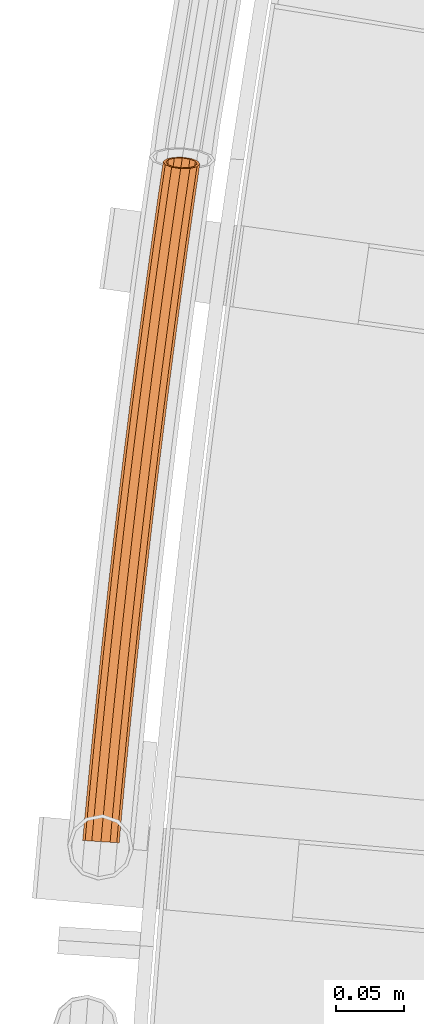
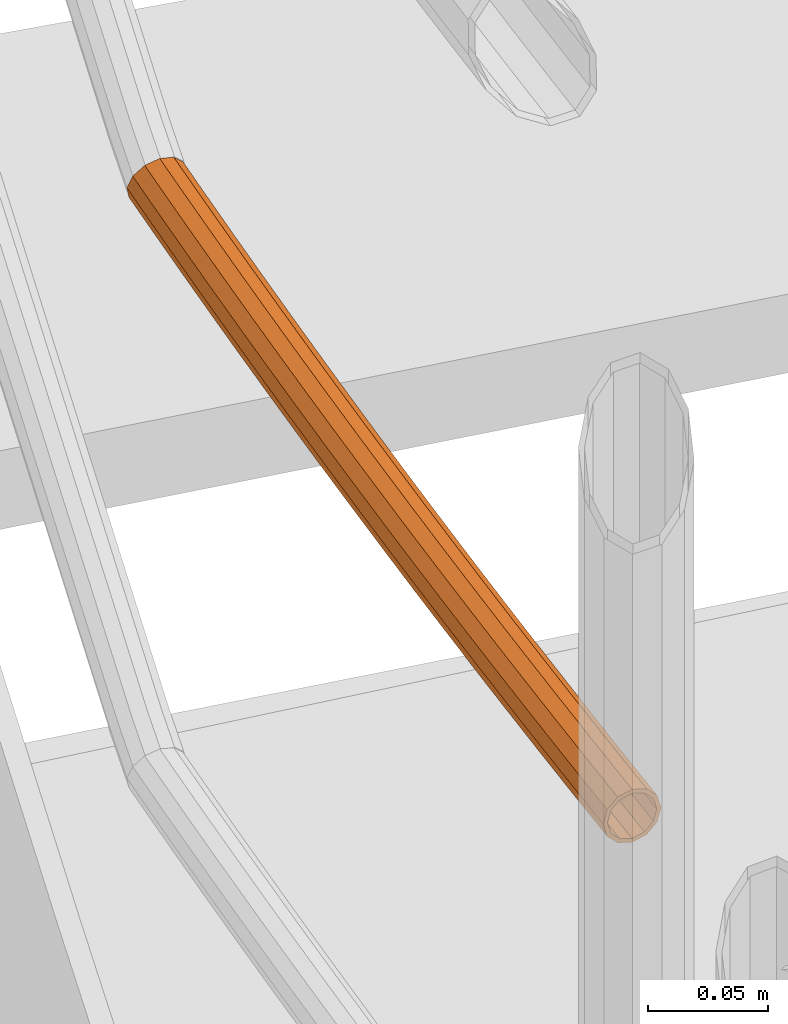
# One storey, part 59 of 126: 1 proxy.
"""IFC2X3 building model written with IfcOpenShell, lengths in millimetres."""

from ifc_helpers import new_model, si_unit, origin, origin_with_axes, place, context, project, spatial, faceted_brep, material, element, save


model = new_model("IFC2X3")

# Units and contexts
context_of_model_1 = context(None, 3, precision=0.1, world=origin())
context_of_model_2 = context(None, 3, precision=0.1, world=origin())
ifc_project = project(units=[si_unit("LENGTHUNIT", "METRE", prefix="MILLI"), si_unit("AREAUNIT", "SQUARE_METRE", prefix="CENTI"), si_unit("VOLUMEUNIT", "CUBIC_METRE", prefix="CENTI"), si_unit("MASSUNIT", "GRAM", prefix="KILO")], contexts=[context_of_model_1, context_of_model_2])

# Site, building, storey
site_placement = place(None, origin_with_axes())
site = spatial("IfcSite", under=ifc_project, at=site_placement, CompositionType="ELEMENT")
building_placement = place(site_placement, origin_with_axes())
building = spatial("IfcBuilding", under=site, at=building_placement, CompositionType="ELEMENT")
storey_placement = place(building_placement, origin_with_axes())
storey = spatial("IfcBuildingStorey", under=building, at=storey_placement, CompositionType="ELEMENT")

# Proxy
ifc_material = material(Name="S235JRG2")
proxy_placement = place(storey_placement, origin_with_axes())
element("IfcBuildingElementProxy", 1, at=proxy_placement, inside=storey, material=ifc_material, context=context_of_model_2, shape_type="Brep", body=[
    faceted_brep([(-835.646, 8812.6734, 6295.5551), (-833.8515, 8812.5095, 6288.8301), (-834.8889, 8800.9315, 6288.8301), (-836.6876, 8801.0484, 6295.5551), (-828.9489, 8812.0616, 6283.907), (-829.9748, 8800.612, 6283.907), (-822.2518, 8811.4498, 6282.1051), (-823.262, 8800.1755, 6282.1051), (-815.5547, 8810.8379, 6283.907), (-816.5491, 8799.7391, 6283.907), (-810.652, 8810.39, 6288.8301), (-811.635, 8799.4196, 6288.8301), (-808.8575, 8810.2261, 6295.5551), (-809.8363, 8799.3026, 6295.5551), (-810.652, 8810.39, 6302.2801), (-811.635, 8799.4196, 6302.2801), (-815.5547, 8810.8379, 6307.2031), (-816.5491, 8799.7391, 6307.2031), (-822.2518, 8811.4498, 6309.0051), (-823.262, 8800.1755, 6309.0051), (-828.9489, 8812.0616, 6307.2031), (-829.9748, 8800.612, 6307.2031), (-833.8515, 8812.5095, 6302.2801), (-834.8889, 8800.9315, 6302.2801), (-833.6543, 8812.4915, 6295.5551), (-832.1267, 8812.3519, 6301.2801), (-833.16, 8800.8191, 6301.2801), (-834.6912, 8800.9186, 6295.5551), (-827.9531, 8811.9706, 6305.4711), (-828.9766, 8800.5471, 6305.4711), (-822.2518, 8811.4498, 6307.0051), (-823.262, 8800.1755, 6307.0051), (-816.5505, 8810.9289, 6305.4711), (-817.5473, 8799.804, 6305.4711), (-812.3769, 8810.5476, 6301.2801), (-813.3639, 8799.532, 6301.2801), (-810.8493, 8810.408, 6295.5551), (-811.8327, 8799.4324, 6295.5551), (-812.3769, 8810.5476, 6289.8301), (-813.3639, 8799.532, 6289.8301), (-816.5505, 8810.9289, 6285.6391), (-817.5473, 8799.804, 6285.6391), (-822.2518, 8811.4498, 6284.1051), (-823.262, 8800.1755, 6284.1051), (-827.9531, 8811.9706, 6285.6391), (-828.9766, 8800.5471, 6285.6391), (-832.1267, 8812.3519, 6289.8301), (-833.16, 8800.8191, 6289.8301), (-832.7729, 8843.5281, 6295.5551), (-830.979, 8843.3579, 6288.8301), (-826.0779, 8842.8929, 6283.907), (-819.383, 8842.2577, 6282.1051), (-812.688, 8841.6225, 6283.907), (-807.787, 8841.1575, 6288.8301), (-805.9931, 8840.9873, 6295.5551), (-807.787, 8841.1575, 6302.2801), (-812.688, 8841.6225, 6307.2031), (-819.383, 8842.2577, 6309.0051), (-826.0779, 8842.8929, 6307.2031), (-830.979, 8843.3579, 6302.2801), (-830.7818, 8843.3392, 6295.5551), (-829.2546, 8843.1943, 6301.2801), (-825.0824, 8842.7985, 6305.4711), (-819.383, 8842.2577, 6307.0051), (-813.6836, 8841.7169, 6305.4711), (-809.5113, 8841.3211, 6301.2801), (-807.9841, 8841.1762, 6295.5551), (-809.5113, 8841.3211, 6289.8301), (-813.6836, 8841.7169, 6285.6391), (-819.383, 8842.2577, 6284.1051), (-825.0824, 8842.7985, 6285.6391), (-829.2546, 8843.1943, 6289.8301), (-829.792, 8874.3726, 6295.5551), (-827.9987, 8874.1961, 6288.8301), (-823.0993, 8873.714, 6283.907), (-816.4066, 8873.0554, 6282.1051), (-809.714, 8872.3969, 6283.907), (-804.8146, 8871.9147, 6288.8301), (-803.0213, 8871.7383, 6295.5551), (-804.8146, 8871.9147, 6302.2801), (-809.714, 8872.3969, 6307.2031), (-816.4066, 8873.0554, 6309.0051), (-823.0993, 8873.714, 6307.2031), (-827.9987, 8874.1961, 6302.2801), (-827.8016, 8874.1767, 6295.5551), (-826.275, 8874.0265, 6301.2801), (-822.1041, 8873.6161, 6305.4711), (-816.4066, 8873.0554, 6307.0051), (-810.7091, 8872.4948, 6305.4711), (-806.5383, 8872.0844, 6301.2801), (-805.0117, 8871.9341, 6295.5551), (-806.5383, 8872.0844, 6289.8301), (-810.7091, 8872.4948, 6285.6391), (-816.4066, 8873.0554, 6284.1051), (-822.1041, 8873.6161, 6285.6391), (-826.275, 8874.0265, 6289.8301), (-826.7035, 8905.2065, 6295.5551), (-824.9108, 8905.0238, 6288.8301), (-820.0132, 8904.5246, 6283.907), (-813.3228, 8903.8426, 6282.1051), (-806.6325, 8903.1607, 6283.907), (-801.7348, 8902.6615, 6288.8301), (-799.9421, 8902.4787, 6295.5551), (-801.7348, 8902.6615, 6302.2801), (-806.6325, 8903.1607, 6307.2031), (-813.3228, 8903.8426, 6309.0051), (-820.0132, 8904.5246, 6307.2031), (-824.9108, 8905.0238, 6302.2801), (-824.7138, 8905.0037, 6295.5551), (-823.1877, 8904.8481, 6301.2801), (-819.0183, 8904.4231, 6305.4711), (-813.3228, 8903.8426, 6307.0051), (-807.6273, 8903.2621, 6305.4711), (-803.4579, 8902.8371, 6301.2801), (-801.9318, 8902.6815, 6295.5551), (-803.4579, 8902.8371, 6289.8301), (-807.6273, 8903.2621, 6285.6391), (-813.3228, 8903.8426, 6284.1051), (-819.0183, 8904.4231, 6285.6391), (-823.1877, 8904.8481, 6289.8301), (-823.5074, 8936.0294, 6295.5551), (-821.7154, 8935.8404, 6288.8301), (-816.8195, 8935.3241, 6283.907), (-810.1315, 8934.6188, 6282.1051), (-803.4436, 8933.9135, 6283.907), (-798.5477, 8933.3972, 6288.8301), (-796.7557, 8933.2082, 6295.5551), (-798.5477, 8933.3972, 6302.2801), (-803.4436, 8933.9135, 6307.2031), (-810.1315, 8934.6188, 6309.0051), (-816.8195, 8935.3241, 6307.2031), (-821.7154, 8935.8404, 6302.2801), (-821.5184, 8935.8197, 6295.5551), (-819.9929, 8935.6588, 6301.2801), (-815.825, 8935.2192, 6305.4711), (-810.1315, 8934.6188, 6307.0051), (-804.4381, 8934.0184, 6305.4711), (-800.2702, 8933.5789, 6301.2801), (-798.7447, 8933.418, 6295.5551), (-800.2702, 8933.5789, 6289.8301), (-804.4381, 8934.0184, 6285.6391), (-810.1315, 8934.6188, 6284.1051), (-815.825, 8935.2192, 6285.6391), (-819.9929, 8935.6588, 6289.8301), (-820.2037, 8966.841, 6295.5551), (-818.4124, 8966.6457, 6288.8301), (-813.5183, 8966.1123, 6283.907), (-806.8329, 8965.3837, 6282.1051), (-800.1474, 8964.6551, 6283.907), (-795.2534, 8964.1217, 6288.8301), (-793.462, 8963.9265, 6295.5551), (-795.2534, 8964.1217, 6302.2801), (-800.1474, 8964.6551, 6307.2031), (-806.8329, 8965.3837, 6309.0051), (-813.5183, 8966.1123, 6307.2031), (-818.4124, 8966.6457, 6302.2801), (-818.2155, 8966.6243, 6295.5551), (-816.6905, 8966.4581, 6301.2801), (-812.5242, 8966.004, 6305.4711), (-806.8329, 8965.3837, 6307.0051), (-801.1416, 8964.7634, 6305.4711), (-796.9752, 8964.3094, 6301.2801), (-795.4503, 8964.1431, 6295.5551), (-796.9752, 8964.3094, 6289.8301), (-801.1416, 8964.7634, 6285.6391), (-806.8329, 8965.3837, 6284.1051), (-812.5242, 8966.004, 6285.6391), (-816.6905, 8966.4581, 6289.8301), (-816.7925, 8997.6408, 6295.5551), (-815.0018, 8997.4393, 6288.8301), (-810.1097, 8996.8889, 6283.907), (-803.4268, 8996.1369, 6282.1051), (-796.744, 8995.3849, 6283.907), (-791.8518, 8994.8345, 6288.8301), (-790.0611, 8994.633, 6295.5551), (-791.8518, 8994.8345, 6302.2801), (-796.744, 8995.3849, 6307.2031), (-803.4268, 8996.1369, 6309.0051), (-810.1097, 8996.8889, 6307.2031), (-815.0018, 8997.4393, 6302.2801), (-814.805, 8997.4172, 6295.5551), (-813.2806, 8997.2457, 6301.2801), (-809.1159, 8996.777, 6305.4711), (-803.4268, 8996.1369, 6307.0051), (-797.7377, 8995.4968, 6305.4711), (-793.573, 8995.0281, 6301.2801), (-792.0486, 8994.8566, 6295.5551), (-793.573, 8995.0281, 6289.8301), (-797.7377, 8995.4968, 6285.6391), (-803.4268, 8996.1369, 6284.1051), (-809.1159, 8996.777, 6285.6391), (-813.2806, 8997.2457, 6289.8301), (-813.2738, 9028.4286, 6295.5551), (-811.4838, 9028.2208, 6288.8301), (-806.5936, 9027.6533, 6283.907), (-799.9134, 9026.878, 6282.1051), (-793.2333, 9026.1027, 6283.907), (-788.343, 9025.5352, 6288.8301), (-786.5531, 9025.3274, 6295.5551), (-788.343, 9025.5352, 6302.2801), (-793.2333, 9026.1027, 6307.2031), (-799.9134, 9026.878, 6309.0051), (-806.5936, 9027.6533, 6307.2031), (-811.4838, 9028.2208, 6302.2801), (-811.2871, 9028.198, 6295.5551), (-809.7633, 9028.0212, 6301.2801), (-805.6003, 9027.538, 6305.4711), (-799.9134, 9026.878, 6307.0051), (-794.2266, 9026.218, 6305.4711), (-790.0635, 9025.7349, 6301.2801), (-788.5398, 9025.558, 6295.5551), (-790.0635, 9025.7349, 6289.8301), (-794.2266, 9026.218, 6285.6391), (-799.9134, 9026.878, 6284.1051), (-805.6003, 9027.538, 6285.6391), (-809.7633, 9028.0212, 6289.8301), (-809.6476, 9059.2039, 6295.5551), (-807.8584, 9058.9899, 6288.8301), (-802.9702, 9058.4053, 6283.907), (-796.2928, 9057.6067, 6282.1051), (-789.6154, 9056.8081, 6283.907), (-784.7271, 9056.2235, 6288.8301), (-782.9379, 9056.0095, 6295.5551), (-784.7271, 9056.2235, 6302.2801), (-789.6154, 9056.8081, 6307.2031), (-796.2928, 9057.6067, 6309.0051), (-802.9702, 9058.4053, 6307.2031), (-807.8584, 9058.9899, 6302.2801), (-807.6618, 9058.9664, 6295.5551), (-806.1386, 9058.7842, 6301.2801), (-801.9773, 9058.2865, 6305.4711), (-796.2928, 9057.6067, 6307.0051), (-790.6083, 9056.9268, 6305.4711), (-786.4469, 9056.4291, 6301.2801), (-784.9238, 9056.247, 6295.5551), (-786.4469, 9056.4291, 6289.8301), (-790.6083, 9056.9268, 6285.6391), (-796.2928, 9057.6067, 6284.1051), (-801.9773, 9058.2865, 6285.6391), (-806.1386, 9058.7842, 6289.8301), (-805.9141, 9089.9663, 6295.5551), (-804.1256, 9089.7461, 6288.8301), (-799.2395, 9089.1444, 6283.907), (-792.5649, 9088.3225, 6282.1051), (-785.8903, 9087.5006, 6283.907), (-781.0041, 9086.8989, 6288.8301), (-779.2157, 9086.6787, 6295.5551), (-781.0041, 9086.8989, 6302.2801), (-785.8903, 9087.5006, 6307.2031), (-792.5649, 9088.3225, 6309.0051), (-799.2395, 9089.1444, 6307.2031), (-804.1256, 9089.7461, 6302.2801), (-803.9291, 9089.7219, 6295.5551), (-802.4065, 9089.5344, 6301.2801), (-798.247, 9089.0222, 6305.4711), (-792.5649, 9088.3225, 6307.0051), (-786.8828, 9087.6228, 6305.4711), (-782.7232, 9087.1106, 6301.2801), (-781.2007, 9086.9231, 6295.5551), (-782.7232, 9087.1106, 6289.8301), (-786.8828, 9087.6228, 6285.6391), (-792.5649, 9088.3225, 6284.1051), (-798.247, 9089.0222, 6285.6391), (-802.4065, 9089.5344, 6289.8301), (-802.0731, 9120.7155, 6295.5551), (-800.2855, 9120.4891, 6288.8301), (-795.4015, 9119.8703, 6283.907), (-788.7298, 9119.0251, 6282.1051), (-782.0581, 9118.1799, 6283.907), (-777.1741, 9117.5612, 6288.8301), (-775.3864, 9117.3347, 6295.5551), (-777.1741, 9117.5612, 6302.2801), (-782.0581, 9118.1799, 6307.2031), (-788.7298, 9119.0251, 6309.0051), (-795.4015, 9119.8703, 6307.2031), (-800.2855, 9120.4891, 6302.2801), (-800.089, 9120.4642, 6295.5551), (-798.5672, 9120.2714, 6301.2801), (-794.4094, 9119.7446, 6305.4711), (-788.7298, 9119.0251, 6307.0051), (-783.0502, 9118.3056, 6305.4711), (-778.8924, 9117.7789, 6301.2801), (-777.3705, 9117.5861, 6295.5551), (-778.8924, 9117.7789, 6289.8301), (-783.0502, 9118.3056, 6285.6391), (-788.7298, 9119.0251, 6284.1051), (-794.4094, 9119.7446, 6285.6391), (-798.5672, 9120.2714, 6289.8301), (-798.1249, 9151.4512, 6295.5551), (-796.338, 9151.2184, 6288.8301), (-791.4562, 9150.5827, 6283.907), (-784.7875, 9149.7142, 6282.1051), (-778.1188, 9148.8457, 6283.907), (-773.237, 9148.2099, 6288.8301), (-771.4501, 9147.9772, 6295.5551), (-773.237, 9148.2099, 6302.2801), (-778.1188, 9148.8457, 6307.2031), (-784.7875, 9149.7142, 6309.0051), (-791.4562, 9150.5827, 6307.2031), (-796.338, 9151.2184, 6302.2801), (-796.1417, 9151.1929, 6295.5551), (-794.6205, 9150.9948, 6301.2801), (-790.4646, 9150.4535, 6305.4711), (-784.7875, 9149.7142, 6307.0051), (-779.1105, 9148.9749, 6305.4711), (-774.9546, 9148.4336, 6301.2801), (-773.4334, 9148.2355, 6295.5551), (-774.9546, 9148.4336, 6289.8301), (-779.1105, 9148.9749, 6285.6391), (-784.7875, 9149.7142, 6284.1051), (-790.4646, 9150.4535, 6285.6391), (-794.6205, 9150.9948, 6289.8301), (-794.0694, 9182.1728, 6295.5551), (-792.2834, 9181.9339, 6288.8301), (-787.4038, 9181.2811, 6283.907), (-780.7382, 9180.3893, 6282.1051), (-774.0726, 9179.4975, 6283.907), (-769.193, 9178.8447, 6288.8301), (-767.4069, 9178.6058, 6295.5551), (-769.193, 9178.8447, 6302.2801), (-774.0726, 9179.4975, 6307.2031), (-780.7382, 9180.3893, 6309.0051), (-787.4038, 9181.2811, 6307.2031), (-792.2834, 9181.9339, 6302.2801), (-792.0871, 9181.9076, 6295.5551), (-790.5666, 9181.7042, 6301.2801), (-786.4126, 9181.1485, 6305.4711), (-780.7382, 9180.3893, 6307.0051), (-775.0637, 9179.6302, 6305.4711), (-770.9097, 9179.0744, 6301.2801), (-769.3893, 9178.871, 6295.5551), (-770.9097, 9179.0744, 6289.8301), (-775.0637, 9179.6302, 6285.6391), (-780.7382, 9180.3893, 6284.1051), (-786.4126, 9181.1485, 6285.6391), (-790.5666, 9181.7042, 6289.8301), (-789.9067, 9212.8801, 6295.5551), (-788.1215, 9212.6349, 6288.8301), (-783.2442, 9211.9651, 6283.907), (-776.5818, 9211.0501, 6282.1051), (-769.9193, 9210.1351, 6283.907), (-765.042, 9209.4652, 6288.8301), (-763.2568, 9209.2201, 6295.5551), (-765.042, 9209.4652, 6302.2801), (-769.9193, 9210.1351, 6307.2031), (-776.5818, 9211.0501, 6309.0051), (-783.2442, 9211.9651, 6307.2031), (-788.1215, 9212.6349, 6302.2801), (-787.9253, 9212.608, 6295.5551), (-786.4056, 9212.3993, 6301.2801), (-782.2535, 9211.829, 6305.4711), (-776.5818, 9211.0501, 6307.0051), (-770.91, 9210.2711, 6305.4711), (-766.758, 9209.7009, 6301.2801), (-765.2382, 9209.4922, 6295.5551), (-766.758, 9209.7009, 6289.8301), (-770.91, 9210.2711, 6285.6391), (-776.5818, 9211.0501, 6284.1051), (-782.2535, 9211.829, 6285.6391), (-786.4056, 9212.3993, 6289.8301), (-785.6368, 9243.5727, 6295.5551), (-783.8525, 9243.3213, 6288.8301), (-778.9776, 9242.6344, 6283.907), (-772.3184, 9241.6962, 6282.1051), (-765.6591, 9240.7579, 6283.907), (-760.7842, 9240.0711, 6288.8301), (-758.9999, 9239.8197, 6295.5551), (-760.7842, 9240.0711, 6302.2801), (-765.6591, 9240.7579, 6307.2031), (-772.3184, 9241.6962, 6309.0051), (-778.9776, 9242.6344, 6307.2031), (-783.8525, 9243.3213, 6302.2801), (-783.6564, 9243.2937, 6295.5551), (-782.1374, 9243.0797, 6301.2801), (-777.9874, 9242.4949, 6305.4711), (-772.3184, 9241.6962, 6307.0051), (-766.6494, 9240.8974, 6305.4711), (-762.4994, 9240.3127, 6301.2801), (-760.9803, 9240.0987, 6295.5551), (-762.4994, 9240.3127, 6289.8301), (-766.6494, 9240.8974, 6285.6391), (-772.3184, 9241.6962, 6284.1051), (-777.9874, 9242.4949, 6285.6391), (-782.1374, 9243.0797, 6289.8301), (-781.2599, 9274.2502, 6295.5551), (-779.4764, 9273.9926, 6288.8301), (-774.6039, 9273.2887, 6283.907), (-767.948, 9272.3272, 6282.1051), (-761.2921, 9271.3657, 6283.907), (-756.4196, 9270.6618, 6288.8301), (-754.6362, 9270.4042, 6295.5551), (-756.4196, 9270.6618, 6302.2801), (-761.2921, 9271.3657, 6307.2031), (-767.948, 9272.3272, 6309.0051), (-774.6039, 9273.2887, 6307.2031), (-779.4764, 9273.9926, 6302.2801), (-779.2804, 9273.9643, 6295.5551), (-777.7622, 9273.7449, 6301.2801), (-773.6142, 9273.1457, 6305.4711), (-767.948, 9272.3272, 6307.0051), (-762.2818, 9271.5087, 6305.4711), (-758.1339, 9270.9095, 6301.2801), (-756.6156, 9270.6901, 6295.5551), (-758.1339, 9270.9095, 6289.8301), (-762.2818, 9271.5087, 6285.6391), (-767.948, 9272.3272, 6284.1051), (-773.6142, 9273.1457, 6285.6391), (-777.7622, 9273.7449, 6289.8301), (-777.4914, 9300.0193, 6295.5551), (-775.3786, 9302.0134, 6288.8301), (-770.224, 9303.2387, 6283.907), (-766.005, 9303.3179, 6282.7915), (-763.4708, 9302.9428, 6282.1051), (-756.8183, 9301.9581, 6283.907), (-755.0955, 9301.703, 6285.6486), (-752.0565, 9300.4971, 6288.8301), (-750.5613, 9298.2683, 6295.5551), (-752.6741, 9296.2742, 6302.2801), (-757.8287, 9295.0489, 6307.2031), (-764.6439, 9294.9209, 6309.0051), (-771.2937, 9295.9244, 6307.2031), (-775.9962, 9297.7905, 6302.2801), (-775.4891, 9299.8891, 6295.5551), (-774.2163, 9297.9917, 6301.2801), (-770.213, 9296.4031, 6305.4711), (-764.5521, 9295.5488, 6307.0051), (-758.7502, 9295.6578, 6305.4711), (-754.3621, 9296.7009, 6301.2801), (-752.5636, 9298.3985, 6295.5551), (-753.8364, 9300.2958, 6289.8301), (-757.8397, 9301.8845, 6285.6391), (-763.5006, 9302.7387, 6284.1051), (-769.3025, 9302.6298, 6285.6391), (-773.6906, 9301.5867, 6289.8301), (-763.4073, 9303.3666, 6282.1051), (-756.7576, 9302.3631, 6283.907)], [[[0, 1, 2, 3]], [[1, 4, 5, 2]], [[4, 6, 7, 5]], [[6, 8, 9, 7]], [[8, 10, 11, 9]], [[10, 12, 13, 11]], [[12, 14, 15, 13]], [[14, 16, 17, 15]], [[16, 18, 19, 17]], [[18, 20, 21, 19]], [[20, 22, 23, 21]], [[0, 3, 23, 22]], [[24, 25, 26, 27]], [[25, 28, 29, 26]], [[28, 30, 31, 29]], [[30, 32, 33, 31]], [[32, 34, 35, 33]], [[34, 36, 37, 35]], [[36, 38, 39, 37]], [[38, 40, 41, 39]], [[40, 42, 43, 41]], [[42, 44, 45, 43]], [[44, 46, 47, 45]], [[24, 27, 47, 46]], [[0, 48, 49, 1]], [[1, 49, 50, 4]], [[4, 50, 51, 6]], [[6, 51, 52, 8]], [[8, 52, 53, 10]], [[10, 53, 54, 12]], [[12, 54, 55, 14]], [[14, 55, 56, 16]], [[16, 56, 57, 18]], [[18, 57, 58, 20]], [[20, 58, 59, 22]], [[22, 59, 48, 0]], [[24, 60, 61, 25]], [[25, 61, 62, 28]], [[28, 62, 63, 30]], [[30, 63, 64, 32]], [[32, 64, 65, 34]], [[34, 65, 66, 36]], [[36, 66, 67, 38]], [[38, 67, 68, 40]], [[40, 68, 69, 42]], [[42, 69, 70, 44]], [[44, 70, 71, 46]], [[46, 71, 60, 24]], [[48, 72, 73, 49]], [[49, 73, 74, 50]], [[50, 74, 75, 51]], [[51, 75, 76, 52]], [[52, 76, 77, 53]], [[53, 77, 78, 54]], [[54, 78, 79, 55]], [[55, 79, 80, 56]], [[56, 80, 81, 57]], [[57, 81, 82, 58]], [[58, 82, 83, 59]], [[59, 83, 72, 48]], [[60, 84, 85, 61]], [[61, 85, 86, 62]], [[62, 86, 87, 63]], [[63, 87, 88, 64]], [[64, 88, 89, 65]], [[65, 89, 90, 66]], [[66, 90, 91, 67]], [[67, 91, 92, 68]], [[68, 92, 93, 69]], [[69, 93, 94, 70]], [[70, 94, 95, 71]], [[71, 95, 84, 60]], [[72, 96, 97, 73]], [[73, 97, 98, 74]], [[74, 98, 99, 75]], [[75, 99, 100, 76]], [[76, 100, 101, 77]], [[77, 101, 102, 78]], [[78, 102, 103, 79]], [[79, 103, 104, 80]], [[80, 104, 105, 81]], [[81, 105, 106, 82]], [[82, 106, 107, 83]], [[83, 107, 96, 72]], [[84, 108, 109, 85]], [[85, 109, 110, 86]], [[86, 110, 111, 87]], [[87, 111, 112, 88]], [[88, 112, 113, 89]], [[89, 113, 114, 90]], [[90, 114, 115, 91]], [[91, 115, 116, 92]], [[92, 116, 117, 93]], [[93, 117, 118, 94]], [[94, 118, 119, 95]], [[95, 119, 108, 84]], [[96, 120, 121, 97]], [[97, 121, 122, 98]], [[98, 122, 123, 99]], [[99, 123, 124, 100]], [[100, 124, 125, 101]], [[101, 125, 126, 102]], [[102, 126, 127, 103]], [[103, 127, 128, 104]], [[104, 128, 129, 105]], [[105, 129, 130, 106]], [[106, 130, 131, 107]], [[107, 131, 120, 96]], [[108, 132, 133, 109]], [[109, 133, 134, 110]], [[110, 134, 135, 111]], [[111, 135, 136, 112]], [[112, 136, 137, 113]], [[113, 137, 138, 114]], [[114, 138, 139, 115]], [[115, 139, 140, 116]], [[116, 140, 141, 117]], [[117, 141, 142, 118]], [[118, 142, 143, 119]], [[119, 143, 132, 108]], [[120, 144, 145, 121]], [[121, 145, 146, 122]], [[122, 146, 147, 123]], [[123, 147, 148, 124]], [[124, 148, 149, 125]], [[125, 149, 150, 126]], [[126, 150, 151, 127]], [[127, 151, 152, 128]], [[128, 152, 153, 129]], [[129, 153, 154, 130]], [[130, 154, 155, 131]], [[131, 155, 144, 120]], [[132, 156, 157, 133]], [[133, 157, 158, 134]], [[134, 158, 159, 135]], [[135, 159, 160, 136]], [[136, 160, 161, 137]], [[137, 161, 162, 138]], [[138, 162, 163, 139]], [[139, 163, 164, 140]], [[140, 164, 165, 141]], [[141, 165, 166, 142]], [[142, 166, 167, 143]], [[143, 167, 156, 132]], [[144, 168, 169, 145]], [[145, 169, 170, 146]], [[146, 170, 171, 147]], [[147, 171, 172, 148]], [[148, 172, 173, 149]], [[149, 173, 174, 150]], [[150, 174, 175, 151]], [[151, 175, 176, 152]], [[152, 176, 177, 153]], [[153, 177, 178, 154]], [[154, 178, 179, 155]], [[155, 179, 168, 144]], [[156, 180, 181, 157]], [[157, 181, 182, 158]], [[158, 182, 183, 159]], [[159, 183, 184, 160]], [[160, 184, 185, 161]], [[161, 185, 186, 162]], [[162, 186, 187, 163]], [[163, 187, 188, 164]], [[164, 188, 189, 165]], [[165, 189, 190, 166]], [[166, 190, 191, 167]], [[167, 191, 180, 156]], [[168, 192, 193, 169]], [[169, 193, 194, 170]], [[170, 194, 195, 171]], [[171, 195, 196, 172]], [[172, 196, 197, 173]], [[173, 197, 198, 174]], [[174, 198, 199, 175]], [[175, 199, 200, 176]], [[176, 200, 201, 177]], [[177, 201, 202, 178]], [[178, 202, 203, 179]], [[179, 203, 192, 168]], [[180, 204, 205, 181]], [[181, 205, 206, 182]], [[182, 206, 207, 183]], [[183, 207, 208, 184]], [[184, 208, 209, 185]], [[185, 209, 210, 186]], [[186, 210, 211, 187]], [[187, 211, 212, 188]], [[188, 212, 213, 189]], [[189, 213, 214, 190]], [[190, 214, 215, 191]], [[191, 215, 204, 180]], [[192, 216, 217, 193]], [[193, 217, 218, 194]], [[194, 218, 219, 195]], [[195, 219, 220, 196]], [[196, 220, 221, 197]], [[197, 221, 222, 198]], [[198, 222, 223, 199]], [[199, 223, 224, 200]], [[200, 224, 225, 201]], [[201, 225, 226, 202]], [[202, 226, 227, 203]], [[203, 227, 216, 192]], [[204, 228, 229, 205]], [[205, 229, 230, 206]], [[206, 230, 231, 207]], [[207, 231, 232, 208]], [[208, 232, 233, 209]], [[209, 233, 234, 210]], [[210, 234, 235, 211]], [[211, 235, 236, 212]], [[212, 236, 237, 213]], [[213, 237, 238, 214]], [[214, 238, 239, 215]], [[215, 239, 228, 204]], [[216, 240, 241, 217]], [[217, 241, 242, 218]], [[218, 242, 243, 219]], [[219, 243, 244, 220]], [[220, 244, 245, 221]], [[221, 245, 246, 222]], [[222, 246, 247, 223]], [[223, 247, 248, 224]], [[224, 248, 249, 225]], [[225, 249, 250, 226]], [[226, 250, 251, 227]], [[227, 251, 240, 216]], [[228, 252, 253, 229]], [[229, 253, 254, 230]], [[230, 254, 255, 231]], [[231, 255, 256, 232]], [[232, 256, 257, 233]], [[233, 257, 258, 234]], [[234, 258, 259, 235]], [[235, 259, 260, 236]], [[236, 260, 261, 237]], [[237, 261, 262, 238]], [[238, 262, 263, 239]], [[239, 263, 252, 228]], [[240, 264, 265, 241]], [[241, 265, 266, 242]], [[242, 266, 267, 243]], [[243, 267, 268, 244]], [[244, 268, 269, 245]], [[245, 269, 270, 246]], [[246, 270, 271, 247]], [[247, 271, 272, 248]], [[248, 272, 273, 249]], [[249, 273, 274, 250]], [[250, 274, 275, 251]], [[251, 275, 264, 240]], [[252, 276, 277, 253]], [[253, 277, 278, 254]], [[254, 278, 279, 255]], [[255, 279, 280, 256]], [[256, 280, 281, 257]], [[257, 281, 282, 258]], [[258, 282, 283, 259]], [[259, 283, 284, 260]], [[260, 284, 285, 261]], [[261, 285, 286, 262]], [[262, 286, 287, 263]], [[263, 287, 276, 252]], [[264, 288, 289, 265]], [[265, 289, 290, 266]], [[266, 290, 291, 267]], [[267, 291, 292, 268]], [[268, 292, 293, 269]], [[269, 293, 294, 270]], [[270, 294, 295, 271]], [[271, 295, 296, 272]], [[272, 296, 297, 273]], [[273, 297, 298, 274]], [[274, 298, 299, 275]], [[275, 299, 288, 264]], [[276, 300, 301, 277]], [[277, 301, 302, 278]], [[278, 302, 303, 279]], [[279, 303, 304, 280]], [[280, 304, 305, 281]], [[281, 305, 306, 282]], [[282, 306, 307, 283]], [[283, 307, 308, 284]], [[284, 308, 309, 285]], [[285, 309, 310, 286]], [[286, 310, 311, 287]], [[287, 311, 300, 276]], [[288, 312, 313, 289]], [[289, 313, 314, 290]], [[290, 314, 315, 291]], [[291, 315, 316, 292]], [[292, 316, 317, 293]], [[293, 317, 318, 294]], [[294, 318, 319, 295]], [[295, 319, 320, 296]], [[296, 320, 321, 297]], [[297, 321, 322, 298]], [[298, 322, 323, 299]], [[299, 323, 312, 288]], [[300, 324, 325, 301]], [[301, 325, 326, 302]], [[302, 326, 327, 303]], [[303, 327, 328, 304]], [[304, 328, 329, 305]], [[305, 329, 330, 306]], [[306, 330, 331, 307]], [[307, 331, 332, 308]], [[308, 332, 333, 309]], [[309, 333, 334, 310]], [[310, 334, 335, 311]], [[311, 335, 324, 300]], [[312, 336, 337, 313]], [[313, 337, 338, 314]], [[314, 338, 339, 315]], [[315, 339, 340, 316]], [[316, 340, 341, 317]], [[317, 341, 342, 318]], [[318, 342, 343, 319]], [[319, 343, 344, 320]], [[320, 344, 345, 321]], [[321, 345, 346, 322]], [[322, 346, 347, 323]], [[323, 347, 336, 312]], [[324, 348, 349, 325]], [[325, 349, 350, 326]], [[326, 350, 351, 327]], [[327, 351, 352, 328]], [[328, 352, 353, 329]], [[329, 353, 354, 330]], [[330, 354, 355, 331]], [[331, 355, 356, 332]], [[332, 356, 357, 333]], [[333, 357, 358, 334]], [[334, 358, 359, 335]], [[335, 359, 348, 324]], [[336, 360, 361, 337]], [[337, 361, 362, 338]], [[338, 362, 363, 339]], [[339, 363, 364, 340]], [[340, 364, 365, 341]], [[341, 365, 366, 342]], [[342, 366, 367, 343]], [[343, 367, 368, 344]], [[344, 368, 369, 345]], [[345, 369, 370, 346]], [[346, 370, 371, 347]], [[347, 371, 360, 336]], [[348, 372, 373, 349]], [[349, 373, 374, 350]], [[350, 374, 375, 351]], [[351, 375, 376, 352]], [[352, 376, 377, 353]], [[353, 377, 378, 354]], [[354, 378, 379, 355]], [[355, 379, 380, 356]], [[356, 380, 381, 357]], [[357, 381, 382, 358]], [[358, 382, 383, 359]], [[359, 383, 372, 348]], [[360, 384, 385, 361]], [[361, 385, 386, 362]], [[362, 386, 387, 363]], [[363, 387, 388, 364]], [[364, 388, 389, 365]], [[365, 389, 390, 366]], [[366, 390, 391, 367]], [[367, 391, 392, 368]], [[368, 392, 393, 369]], [[369, 393, 394, 370]], [[370, 394, 395, 371]], [[371, 395, 384, 360]], [[372, 396, 397, 373]], [[373, 397, 398, 374]], [[374, 398, 399, 375]], [[375, 399, 400, 376]], [[376, 400, 401, 377]], [[377, 401, 402, 378]], [[378, 402, 403, 379]], [[379, 403, 404, 380]], [[380, 404, 405, 381]], [[381, 405, 406, 382]], [[382, 406, 407, 383]], [[383, 407, 396, 372]], [[384, 408, 409, 385]], [[385, 409, 410, 386]], [[386, 410, 411, 412, 387]], [[387, 412, 413, 388]], [[388, 413, 414, 415, 389]], [[389, 415, 416, 390]], [[390, 416, 417, 391]], [[391, 417, 418, 392]], [[392, 418, 419, 393]], [[393, 419, 420, 394]], [[394, 420, 421, 395]], [[384, 395, 421, 408]], [[396, 422, 423, 397]], [[397, 423, 424, 398]], [[398, 424, 425, 399]], [[399, 425, 426, 400]], [[400, 426, 427, 401]], [[401, 427, 428, 402]], [[402, 428, 429, 403]], [[403, 429, 430, 404]], [[404, 430, 431, 405]], [[405, 431, 432, 406]], [[406, 432, 433, 407]], [[396, 407, 433, 422]], [[411, 434, 412]], [[412, 434, 435, 413]], [[413, 435, 414]], [[7, 9, 11, 13, 15, 17, 19, 21, 23, 3, 2, 5], [26, 29, 31, 33, 35, 37, 39, 41, 43, 45, 47, 27]], [[408, 421, 420, 419, 418, 417, 416, 415, 414, 435, 434, 411, 410, 409], [422, 433, 432, 431, 430, 429, 428, 427, 426, 425, 424, 423]]]),
])

save(model, "model.ifc")
